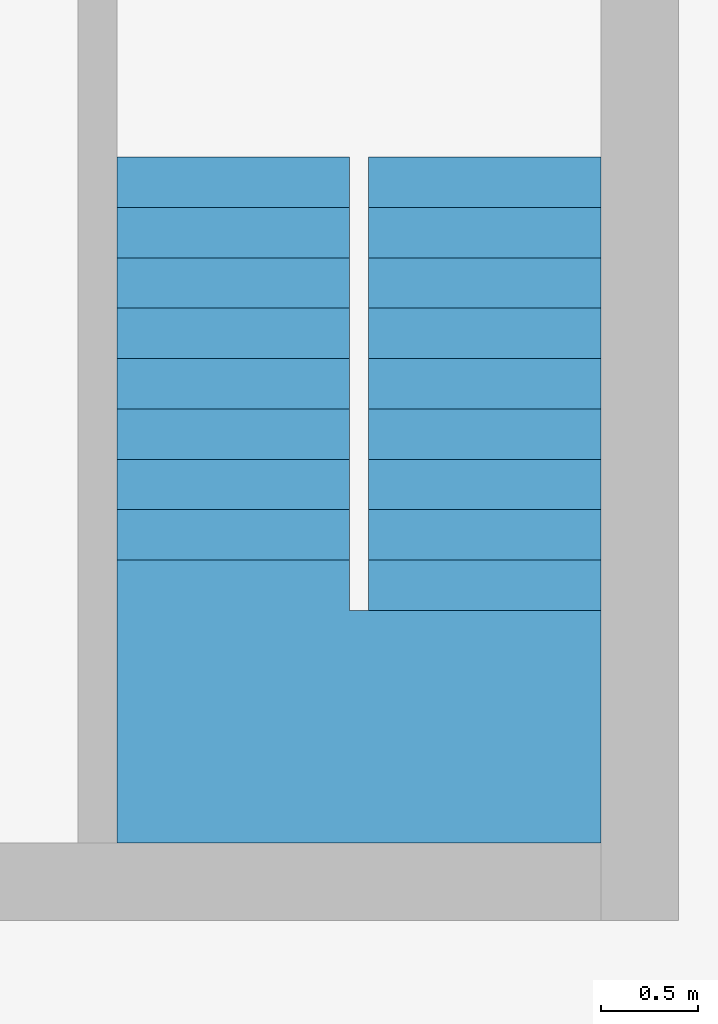
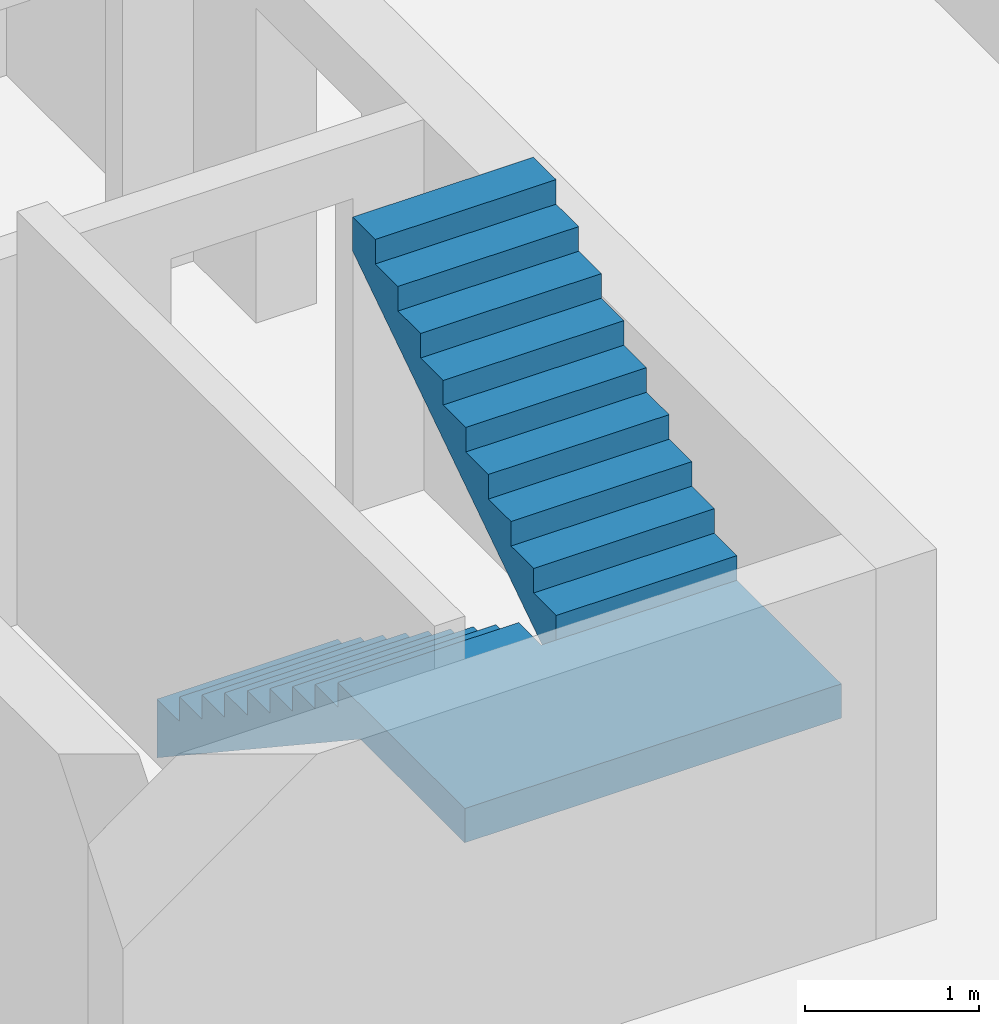
# One storey, part 2 of 2: 1 stair.
"""IFC2X3 building model written with IfcOpenShell, lengths in metres."""

from ifc_helpers import new_model, entity, si_unit, converted_unit, frame, origin, place, context, subcontext, project, spatial, faceted_brep, material, element, save


model = new_model("IFC2X3")

# Units and contexts
model_context = context("Model", 3, precision=1e-05, world=origin())
body_context = subcontext(model_context, "Body", "Model", "MODEL_VIEW")
ifc_project = project(units=[si_unit("LENGTHUNIT", "METRE"), si_unit("AREAUNIT", "SQUARE_METRE"), si_unit("VOLUMEUNIT", "CUBIC_METRE"), si_unit("MASSUNIT", "GRAM", prefix="KILO"), converted_unit("PLANEANGLEUNIT", "DEGREE", entity("IfcPlaneAngleMeasure", 0.0174532925199433), si_unit("PLANEANGLEUNIT", "RADIAN"), dimensions=[0, 0, 0, 0, 0, 0, 0])], contexts=[model_context])

# Site, building, storey
site_placement = place(None, origin())
site = spatial("IfcSite", under=ifc_project, at=site_placement, CompositionType="ELEMENT")
building_placement = place(site_placement, origin())
building = spatial("IfcBuilding", under=site, at=building_placement, CompositionType="ELEMENT")
storey_placement = place(building_placement, frame((0.0, 0.0, -3.1)))
storey = spatial("IfcBuildingStorey", under=building, at=storey_placement, Name="Untergeschoss", CompositionType="ELEMENT", Elevation=-3.1)

# Stair
ifc_material = material(Name="FT_STB C45")
stair_placement = place(storey_placement, frame((22.5, 5.4, -0.240467261695489)))
element("IfcStair", 1, at=stair_placement, inside=storey, material=ifc_material, ShapeType="NOTDEFINED", context=body_context, shape_type="Brep", body=[
    faceted_brep([(1.3, 3.02010000000001, 3.11824503947327), (2.5, 3.02010000000001, 3.11824503947327), (2.5, 3.28010000000001, 3.11824503947327), (1.3, 3.28010000000001, 3.11824503947327), (2.5, 3.02010000000001, 3.16824503947327), (1.3, 3.02010000000001, 3.16824503947327), (1.3, 3.28010000000001, 3.16824503947327), (2.5, 3.28010000000001, 3.16824503947327)], [[[0, 1, 2, 3]], [[4, 5, 6, 7]], [[1, 0, 5, 4]], [[2, 1, 4, 7]], [[3, 2, 7, 6]], [[0, 3, 6, 5]]], orient=[[False], [False], [False], [False], [False], [False]]),
    faceted_brep([(1.3, 2.76010000000001, 2.94602281725104), (2.5, 2.76010000000001, 2.94602281725104), (2.5, 3.02010000000001, 2.94602281725104), (1.3, 3.02010000000001, 2.94602281725104), (2.5, 2.76010000000001, 2.99602281725104), (1.3, 2.76010000000001, 2.99602281725104), (1.3, 3.02010000000001, 2.99602281725104), (2.5, 3.02010000000001, 2.99602281725104)], [[[0, 1, 2, 3]], [[4, 5, 6, 7]], [[1, 0, 5, 4]], [[2, 1, 4, 7]], [[3, 2, 7, 6]], [[0, 3, 6, 5]]], orient=[[False], [False], [False], [False], [False], [False]]),
    faceted_brep([(1.3, 2.50010000000001, 2.77380059502882), (2.5, 2.50010000000001, 2.77380059502882), (2.5, 2.76010000000001, 2.77380059502882), (1.3, 2.76010000000001, 2.77380059502882), (2.5, 2.50010000000001, 2.82380059502882), (1.3, 2.50010000000001, 2.82380059502882), (1.3, 2.76010000000001, 2.82380059502882), (2.5, 2.76010000000001, 2.82380059502882)], [[[0, 1, 2, 3]], [[4, 5, 6, 7]], [[1, 0, 5, 4]], [[2, 1, 4, 7]], [[3, 2, 7, 6]], [[0, 3, 6, 5]]], orient=[[False], [False], [False], [False], [False], [False]]),
    faceted_brep([(1.3, 2.24010000000001, 2.6015783728066), (2.5, 2.24010000000001, 2.6015783728066), (2.5, 2.50010000000001, 2.6015783728066), (1.3, 2.50010000000001, 2.6015783728066), (2.5, 2.24010000000001, 2.6515783728066), (1.3, 2.24010000000001, 2.6515783728066), (1.3, 2.50010000000001, 2.6515783728066), (2.5, 2.50010000000001, 2.6515783728066)], [[[0, 1, 2, 3]], [[4, 5, 6, 7]], [[1, 0, 5, 4]], [[2, 1, 4, 7]], [[3, 2, 7, 6]], [[0, 3, 6, 5]]], orient=[[False], [False], [False], [False], [False], [False]]),
    faceted_brep([(1.3, 1.98010000000001, 2.42935615058438), (2.5, 1.98010000000001, 2.42935615058438), (2.5, 2.24010000000001, 2.42935615058438), (1.3, 2.24010000000001, 2.42935615058438), (2.5, 1.98010000000001, 2.47935615058438), (1.3, 1.98010000000001, 2.47935615058438), (1.3, 2.24010000000001, 2.47935615058438), (2.5, 2.24010000000001, 2.47935615058438)], [[[0, 1, 2, 3]], [[4, 5, 6, 7]], [[1, 0, 5, 4]], [[2, 1, 4, 7]], [[3, 2, 7, 6]], [[0, 3, 6, 5]]], orient=[[False], [False], [False], [False], [False], [False]]),
    faceted_brep([(1.3, 1.72010000000001, 2.25713392836215), (2.5, 1.72010000000001, 2.25713392836215), (2.5, 1.98010000000001, 2.25713392836215), (1.3, 1.98010000000001, 2.25713392836215), (2.5, 1.72010000000001, 2.30713392836215), (1.3, 1.72010000000001, 2.30713392836215), (1.3, 1.98010000000001, 2.30713392836215), (2.5, 1.98010000000001, 2.30713392836215)], [[[0, 1, 2, 3]], [[4, 5, 6, 7]], [[1, 0, 5, 4]], [[2, 1, 4, 7]], [[3, 2, 7, 6]], [[0, 3, 6, 5]]], orient=[[False], [False], [False], [False], [False], [False]]),
    faceted_brep([(1.3, 1.46010000000001, 2.08491170613993), (2.5, 1.46010000000001, 2.08491170613993), (2.5, 1.72010000000001, 2.08491170613993), (1.3, 1.72010000000001, 2.08491170613993), (2.5, 1.46010000000001, 2.13491170613993), (1.3, 1.46010000000001, 2.13491170613993), (1.3, 1.72010000000001, 2.13491170613993), (2.5, 1.72010000000001, 2.13491170613993)], [[[0, 1, 2, 3]], [[4, 5, 6, 7]], [[1, 0, 5, 4]], [[2, 1, 4, 7]], [[3, 2, 7, 6]], [[0, 3, 6, 5]]], orient=[[False], [False], [False], [False], [False], [False]]),
    faceted_brep([(1.3, 1.20010000000001, 1.91268948391771), (2.5, 1.20010000000001, 1.91268948391771), (2.5, 1.46010000000001, 1.91268948391771), (1.3, 1.46010000000001, 1.91268948391771), (2.5, 1.20010000000001, 1.96268948391771), (1.3, 1.20010000000001, 1.96268948391771), (1.3, 1.46010000000001, 1.96268948391771), (2.5, 1.46010000000001, 1.96268948391771)], [[[0, 1, 2, 3]], [[4, 5, 6, 7]], [[1, 0, 5, 4]], [[2, 1, 4, 7]], [[3, 2, 7, 6]], [[0, 3, 6, 5]]], orient=[[False], [False], [False], [False], [False], [False]]),
    faceted_brep([(1.201, 1.2, 1.74046726169549), (1.201, 0.0, 1.74046726169549), (2.5, 0.0, 1.74046726169549), (2.5, 1.20010000000001, 1.74046726169549), (1.3, 1.20010000000001, 1.74046726169549), (1.3, 1.2, 1.74046726169549), (1.201, 0.0, 1.79046726169549), (1.201, 1.2, 1.79046726169549), (1.3, 1.2, 1.79046726169549), (1.3, 1.20010000000001, 1.79046726169549), (2.5, 1.20010000000001, 1.79046726169549), (2.5, 0.0, 1.79046726169549)], [[[0, 1, 2, 3, 4, 5]], [[6, 7, 8, 9, 10, 11]], [[1, 0, 7, 6]], [[2, 1, 6, 11]], [[3, 2, 11, 10]], [[4, 3, 10, 9]], [[5, 4, 9, 8]], [[0, 5, 8, 7]]], orient=[[False], [False], [False], [False], [False], [False], [False], [False]]),
    faceted_brep([(1.2, 1.2001, 1.74046726169549), (0.0, 1.2001, 1.74046726169549), (0.0, 0.0, 1.74046726169549), (1.201, 0.0, 1.74046726169549), (1.201, 1.2, 1.74046726169549), (1.2, 1.2, 1.74046726169549), (0.0, 1.2001, 1.79046726169549), (1.2, 1.2001, 1.79046726169549), (1.2, 1.2, 1.79046726169549), (1.201, 1.2, 1.79046726169549), (1.201, 0.0, 1.79046726169549), (0.0, 0.0, 1.79046726169549)], [[[0, 1, 2, 3, 4, 5]], [[6, 7, 8, 9, 10, 11]], [[1, 0, 7, 6]], [[2, 1, 6, 11]], [[3, 2, 11, 10]], [[4, 3, 10, 9]], [[5, 4, 9, 8]], [[0, 5, 8, 7]]], orient=[[False], [False], [False], [False], [False], [False], [False], [False]]),
    faceted_brep([(1.2, 1.4601, 1.74046726169549), (0.0, 1.4601, 1.74046726169549), (0.0, 1.2001, 1.74046726169549), (1.2, 1.2001, 1.74046726169549), (0.0, 1.4601, 1.79046726169549), (1.2, 1.4601, 1.79046726169549), (1.2, 1.2001, 1.79046726169549), (0.0, 1.2001, 1.79046726169549)], [[[0, 1, 2, 3]], [[4, 5, 6, 7]], [[1, 0, 5, 4]], [[2, 1, 4, 7]], [[3, 2, 7, 6]], [[0, 3, 6, 5]]], orient=[[False], [False], [False], [False], [False], [False]]),
    faceted_brep([(1.2, 1.7201, 1.56824503947327), (0.0, 1.7201, 1.56824503947327), (0.0, 1.4601, 1.56824503947327), (1.2, 1.4601, 1.56824503947327), (0.0, 1.7201, 1.61824503947327), (1.2, 1.7201, 1.61824503947327), (1.2, 1.4601, 1.61824503947327), (0.0, 1.4601, 1.61824503947327)], [[[0, 1, 2, 3]], [[4, 5, 6, 7]], [[1, 0, 5, 4]], [[2, 1, 4, 7]], [[3, 2, 7, 6]], [[0, 3, 6, 5]]], orient=[[False], [False], [False], [False], [False], [False]]),
    faceted_brep([(1.2, 1.9801, 1.39602281725104), (0.0, 1.9801, 1.39602281725104), (0.0, 1.7201, 1.39602281725104), (1.2, 1.7201, 1.39602281725104), (0.0, 1.9801, 1.44602281725104), (1.2, 1.9801, 1.44602281725104), (1.2, 1.7201, 1.44602281725104), (0.0, 1.7201, 1.44602281725104)], [[[0, 1, 2, 3]], [[4, 5, 6, 7]], [[1, 0, 5, 4]], [[2, 1, 4, 7]], [[3, 2, 7, 6]], [[0, 3, 6, 5]]], orient=[[False], [False], [False], [False], [False], [False]]),
    faceted_brep([(1.2, 2.2401, 1.22380059502882), (0.0, 2.2401, 1.22380059502882), (0.0, 1.9801, 1.22380059502882), (1.2, 1.9801, 1.22380059502882), (0.0, 2.2401, 1.27380059502882), (1.2, 2.2401, 1.27380059502882), (1.2, 1.9801, 1.27380059502882), (0.0, 1.9801, 1.27380059502882)], [[[0, 1, 2, 3]], [[4, 5, 6, 7]], [[1, 0, 5, 4]], [[2, 1, 4, 7]], [[3, 2, 7, 6]], [[0, 3, 6, 5]]], orient=[[False], [False], [False], [False], [False], [False]]),
    faceted_brep([(1.2, 2.5001, 1.0515783728066), (0.0, 2.5001, 1.0515783728066), (0.0, 2.2401, 1.0515783728066), (1.2, 2.2401, 1.0515783728066), (0.0, 2.5001, 1.1015783728066), (1.2, 2.5001, 1.1015783728066), (1.2, 2.2401, 1.1015783728066), (0.0, 2.2401, 1.1015783728066)], [[[0, 1, 2, 3]], [[4, 5, 6, 7]], [[1, 0, 5, 4]], [[2, 1, 4, 7]], [[3, 2, 7, 6]], [[0, 3, 6, 5]]], orient=[[False], [False], [False], [False], [False], [False]]),
    faceted_brep([(1.2, 2.7601, 0.879356150584377), (0.0, 2.7601, 0.879356150584377), (0.0, 2.5001, 0.879356150584377), (1.2, 2.5001, 0.879356150584377), (0.0, 2.7601, 0.929356150584377), (1.2, 2.7601, 0.929356150584377), (1.2, 2.5001, 0.929356150584377), (0.0, 2.5001, 0.929356150584377)], [[[0, 1, 2, 3]], [[4, 5, 6, 7]], [[1, 0, 5, 4]], [[2, 1, 4, 7]], [[3, 2, 7, 6]], [[0, 3, 6, 5]]], orient=[[False], [False], [False], [False], [False], [False]]),
    faceted_brep([(1.2, 3.0201, 0.707133928362155), (0.0, 3.0201, 0.707133928362155), (0.0, 2.7601, 0.707133928362155), (1.2, 2.7601, 0.707133928362155), (0.0, 3.0201, 0.757133928362155), (1.2, 3.0201, 0.757133928362155), (1.2, 2.7601, 0.757133928362155), (0.0, 2.7601, 0.757133928362155)], [[[0, 1, 2, 3]], [[4, 5, 6, 7]], [[1, 0, 5, 4]], [[2, 1, 4, 7]], [[3, 2, 7, 6]], [[0, 3, 6, 5]]], orient=[[False], [False], [False], [False], [False], [False]]),
    faceted_brep([(1.2, 3.2801, 0.534911706139933), (0.0, 3.2801, 0.534911706139933), (0.0, 3.0201, 0.534911706139933), (1.2, 3.0201, 0.534911706139933), (0.0, 3.2801, 0.584911706139933), (1.2, 3.2801, 0.584911706139933), (1.2, 3.0201, 0.584911706139933), (0.0, 3.0201, 0.584911706139933)], [[[0, 1, 2, 3]], [[4, 5, 6, 7]], [[1, 0, 5, 4]], [[2, 1, 4, 7]], [[3, 2, 7, 6]], [[0, 3, 6, 5]]], orient=[[False], [False], [False], [False], [False], [False]]),
    faceted_brep([(1.2, 3.5401, 0.362689483917711), (0.0, 3.5401, 0.362689483917711), (0.0, 3.2801, 0.362689483917711), (1.2, 3.2801, 0.362689483917711), (0.0, 3.5401, 0.412689483917711), (1.2, 3.5401, 0.412689483917711), (1.2, 3.2801, 0.412689483917711), (0.0, 3.2801, 0.412689483917711)], [[[0, 1, 2, 3]], [[4, 5, 6, 7]], [[1, 0, 5, 4]], [[2, 1, 4, 7]], [[3, 2, 7, 6]], [[0, 3, 6, 5]]], orient=[[False], [False], [False], [False], [False], [False]]),
    faceted_brep([(1.3, 3.28010000000001, 3.29046726169549), (2.5, 3.28010000000001, 3.29046726169549), (2.5, 3.5401, 3.29046726169549), (1.3, 3.5401, 3.29046726169549), (2.5, 3.28010000000001, 3.34046726169549), (1.3, 3.28010000000001, 3.34046726169549), (1.3, 3.5401, 3.34046726169549), (2.5, 3.5401, 3.34046726169549)], [[[0, 1, 2, 3]], [[4, 5, 6, 7]], [[1, 0, 5, 4]], [[2, 1, 4, 7]], [[3, 2, 7, 6]], [[0, 3, 6, 5]]], orient=[[False], [False], [False], [False], [False], [False]]),
    faceted_brep([(2.5, 3.02010000000001, 2.75555555555555), (2.5, 3.28010000000001, 2.92777777777778), (1.3, 3.28010000000001, 2.92777777777778), (1.3, 3.02010000000001, 2.75555555555555), (1.3, 3.02010000000001, 3.11824503947327), (1.3, 3.28010000000001, 3.11824503947327), (2.5, 3.28010000000001, 3.11824503947327), (2.5, 3.02010000000001, 3.11824503947327)], [[[0, 1, 2, 3]], [[4, 5, 6, 7]], [[3, 4, 7, 0]], [[0, 7, 6, 1]], [[1, 6, 5, 2]], [[2, 5, 4, 3]]], orient=[[False], [False], [False], [False], [False], [False]]),
    faceted_brep([(2.5, 2.76010000000001, 2.58333333333333), (2.5, 3.02010000000001, 2.75555555555555), (1.3, 3.02010000000001, 2.75555555555555), (1.3, 2.76010000000001, 2.58333333333333), (1.3, 2.76010000000001, 2.94602281725104), (1.3, 3.02010000000001, 2.94602281725104), (2.5, 3.02010000000001, 2.94602281725104), (2.5, 2.76010000000001, 2.94602281725104)], [[[0, 1, 2, 3]], [[4, 5, 6, 7]], [[3, 4, 7, 0]], [[0, 7, 6, 1]], [[1, 6, 5, 2]], [[2, 5, 4, 3]]], orient=[[False], [False], [False], [False], [False], [False]]),
    faceted_brep([(2.5, 2.50010000000001, 2.41111111111111), (2.5, 2.76010000000001, 2.58333333333333), (1.3, 2.76010000000001, 2.58333333333333), (1.3, 2.50010000000001, 2.41111111111111), (1.3, 2.50010000000001, 2.77380059502882), (1.3, 2.76010000000001, 2.77380059502882), (2.5, 2.76010000000001, 2.77380059502882), (2.5, 2.50010000000001, 2.77380059502882)], [[[0, 1, 2, 3]], [[4, 5, 6, 7]], [[3, 4, 7, 0]], [[0, 7, 6, 1]], [[1, 6, 5, 2]], [[2, 5, 4, 3]]], orient=[[False], [False], [False], [False], [False], [False]]),
    faceted_brep([(2.5, 2.24010000000001, 2.23888888888889), (2.5, 2.50010000000001, 2.41111111111111), (1.3, 2.50010000000001, 2.41111111111111), (1.3, 2.24010000000001, 2.23888888888889), (1.3, 2.24010000000001, 2.6015783728066), (1.3, 2.50010000000001, 2.6015783728066), (2.5, 2.50010000000001, 2.6015783728066), (2.5, 2.24010000000001, 2.6015783728066)], [[[0, 1, 2, 3]], [[4, 5, 6, 7]], [[3, 4, 7, 0]], [[0, 7, 6, 1]], [[1, 6, 5, 2]], [[2, 5, 4, 3]]], orient=[[False], [False], [False], [False], [False], [False]]),
    faceted_brep([(2.5, 1.98010000000001, 2.06666666666667), (2.5, 2.24010000000001, 2.23888888888889), (1.3, 2.24010000000001, 2.23888888888889), (1.3, 1.98010000000001, 2.06666666666667), (1.3, 1.98010000000001, 2.42935615058438), (1.3, 2.24010000000001, 2.42935615058438), (2.5, 2.24010000000001, 2.42935615058438), (2.5, 1.98010000000001, 2.42935615058438)], [[[0, 1, 2, 3]], [[4, 5, 6, 7]], [[3, 4, 7, 0]], [[0, 7, 6, 1]], [[1, 6, 5, 2]], [[2, 5, 4, 3]]], orient=[[False], [False], [False], [False], [False], [False]]),
    faceted_brep([(2.5, 1.72010000000001, 1.89444444444444), (2.5, 1.98010000000001, 2.06666666666667), (1.3, 1.98010000000001, 2.06666666666667), (1.3, 1.72010000000001, 1.89444444444444), (1.3, 1.72010000000001, 2.25713392836215), (1.3, 1.98010000000001, 2.25713392836215), (2.5, 1.98010000000001, 2.25713392836215), (2.5, 1.72010000000001, 2.25713392836215)], [[[0, 1, 2, 3]], [[4, 5, 6, 7]], [[3, 4, 7, 0]], [[0, 7, 6, 1]], [[1, 6, 5, 2]], [[2, 5, 4, 3]]], orient=[[False], [False], [False], [False], [False], [False]]),
    faceted_brep([(2.5, 1.46010000000001, 1.72222222222222), (2.5, 1.72010000000001, 1.89444444444444), (1.3, 1.72010000000001, 1.89444444444444), (1.3, 1.46010000000001, 1.72222222222222), (1.3, 1.46010000000001, 2.08491170613993), (1.3, 1.72010000000001, 2.08491170613993), (2.5, 1.72010000000001, 2.08491170613993), (2.5, 1.46010000000001, 2.08491170613993)], [[[0, 1, 2, 3]], [[4, 5, 6, 7]], [[3, 4, 7, 0]], [[0, 7, 6, 1]], [[1, 6, 5, 2]], [[2, 5, 4, 3]]], orient=[[False], [False], [False], [False], [False], [False]]),
    faceted_brep([(2.5, 1.20010000000001, 1.55), (2.5, 1.46010000000001, 1.72222222222222), (1.3, 1.46010000000001, 1.72222222222222), (1.3, 1.20010000000001, 1.55), (1.3, 1.20010000000001, 1.91268948391771), (1.3, 1.46010000000001, 1.91268948391771), (2.5, 1.46010000000001, 1.91268948391771), (2.5, 1.20010000000001, 1.91268948391771)], [[[0, 1, 2, 3]], [[4, 5, 6, 7]], [[3, 4, 7, 0]], [[0, 7, 6, 1]], [[1, 6, 5, 2]], [[2, 5, 4, 3]]], orient=[[False], [False], [False], [False], [False], [False]]),
    faceted_brep([(1.201, 1.2, 1.55), (1.201, 0.0, 1.55), (2.5, 0.0, 1.55), (2.5, 1.20010000000001, 1.55), (1.3, 1.20010000000001, 1.55), (1.3, 1.2, 1.55), (1.201, 0.0, 1.74046726169549), (1.201, 1.2, 1.74046726169549), (1.3, 1.2, 1.74046726169549), (1.3, 1.20010000000001, 1.74046726169549), (2.5, 1.20010000000001, 1.74046726169549), (2.5, 0.0, 1.74046726169549)], [[[0, 1, 2, 3, 4, 5]], [[6, 7, 8, 9, 10, 11]], [[1, 0, 7, 6]], [[2, 1, 6, 11]], [[3, 2, 11, 10]], [[4, 3, 10, 9]], [[5, 4, 9, 8]], [[0, 5, 8, 7]]], orient=[[False], [False], [False], [False], [False], [False], [False], [False]]),
    faceted_brep([(1.2, 1.2001, 1.55), (0.0, 1.2001, 1.55), (0.0, 0.0, 1.55), (1.201, 0.0, 1.55), (1.201, 1.2, 1.55), (1.2, 1.2, 1.55), (0.0, 1.2001, 1.74046726169549), (1.2, 1.2001, 1.74046726169549), (1.2, 1.2, 1.74046726169549), (1.201, 1.2, 1.74046726169549), (1.201, 0.0, 1.74046726169549), (0.0, 0.0, 1.74046726169549)], [[[0, 1, 2, 3, 4, 5]], [[6, 7, 8, 9, 10, 11]], [[1, 0, 7, 6]], [[2, 1, 6, 11]], [[3, 2, 11, 10]], [[4, 3, 10, 9]], [[5, 4, 9, 8]], [[0, 5, 8, 7]]], orient=[[False], [False], [False], [False], [False], [False], [False], [False]]),
    faceted_brep([(0.0, 1.4601, 1.37777777777778), (0.0, 1.2001, 1.55), (1.2, 1.2001, 1.55), (1.2, 1.4601, 1.37777777777778), (1.2, 1.4601, 1.74046726169549), (1.2, 1.2001, 1.74046726169549), (0.0, 1.2001, 1.74046726169549), (0.0, 1.4601, 1.74046726169549)], [[[0, 1, 2, 3]], [[4, 5, 6, 7]], [[3, 4, 7, 0]], [[0, 7, 6, 1]], [[1, 6, 5, 2]], [[2, 5, 4, 3]]], orient=[[False], [False], [False], [False], [False], [False]]),
    faceted_brep([(0.0, 1.7201, 1.20555555555555), (0.0, 1.4601, 1.37777777777778), (1.2, 1.4601, 1.37777777777778), (1.2, 1.7201, 1.20555555555555), (1.2, 1.7201, 1.56824503947327), (1.2, 1.4601, 1.56824503947327), (0.0, 1.4601, 1.56824503947327), (0.0, 1.7201, 1.56824503947327)], [[[0, 1, 2, 3]], [[4, 5, 6, 7]], [[3, 4, 7, 0]], [[0, 7, 6, 1]], [[1, 6, 5, 2]], [[2, 5, 4, 3]]], orient=[[False], [False], [False], [False], [False], [False]]),
    faceted_brep([(0.0, 1.9801, 1.03333333333333), (0.0, 1.7201, 1.20555555555556), (1.2, 1.7201, 1.20555555555556), (1.2, 1.9801, 1.03333333333333), (1.2, 1.9801, 1.39602281725104), (1.2, 1.7201, 1.39602281725104), (0.0, 1.7201, 1.39602281725104), (0.0, 1.9801, 1.39602281725104)], [[[0, 1, 2, 3]], [[4, 5, 6, 7]], [[3, 4, 7, 0]], [[0, 7, 6, 1]], [[1, 6, 5, 2]], [[2, 5, 4, 3]]], orient=[[False], [False], [False], [False], [False], [False]]),
    faceted_brep([(0.0, 2.2401, 0.86111111111111), (0.0, 1.9801, 1.03333333333333), (1.2, 1.9801, 1.03333333333333), (1.2, 2.2401, 0.86111111111111), (1.2, 2.2401, 1.22380059502882), (1.2, 1.9801, 1.22380059502882), (0.0, 1.9801, 1.22380059502882), (0.0, 2.2401, 1.22380059502882)], [[[0, 1, 2, 3]], [[4, 5, 6, 7]], [[3, 4, 7, 0]], [[0, 7, 6, 1]], [[1, 6, 5, 2]], [[2, 5, 4, 3]]], orient=[[False], [False], [False], [False], [False], [False]]),
    faceted_brep([(0.0, 2.5001, 0.688888888888889), (0.0, 2.2401, 0.861111111111111), (1.2, 2.2401, 0.861111111111111), (1.2, 2.5001, 0.688888888888889), (1.2, 2.5001, 1.0515783728066), (1.2, 2.2401, 1.0515783728066), (0.0, 2.2401, 1.0515783728066), (0.0, 2.5001, 1.0515783728066)], [[[0, 1, 2, 3]], [[4, 5, 6, 7]], [[3, 4, 7, 0]], [[0, 7, 6, 1]], [[1, 6, 5, 2]], [[2, 5, 4, 3]]], orient=[[False], [False], [False], [False], [False], [False]]),
    faceted_brep([(0.0, 2.7601, 0.516666666666666), (0.0, 2.5001, 0.688888888888889), (1.2, 2.5001, 0.688888888888889), (1.2, 2.7601, 0.516666666666666), (1.2, 2.7601, 0.879356150584377), (1.2, 2.5001, 0.879356150584377), (0.0, 2.5001, 0.879356150584377), (0.0, 2.7601, 0.879356150584377)], [[[0, 1, 2, 3]], [[4, 5, 6, 7]], [[3, 4, 7, 0]], [[0, 7, 6, 1]], [[1, 6, 5, 2]], [[2, 5, 4, 3]]], orient=[[False], [False], [False], [False], [False], [False]]),
    faceted_brep([(0.0, 3.0201, 0.344444444444444), (0.0, 2.7601, 0.516666666666667), (1.2, 2.7601, 0.516666666666667), (1.2, 3.0201, 0.344444444444444), (1.2, 3.0201, 0.707133928362155), (1.2, 2.7601, 0.707133928362155), (0.0, 2.7601, 0.707133928362155), (0.0, 3.0201, 0.707133928362155)], [[[0, 1, 2, 3]], [[4, 5, 6, 7]], [[3, 4, 7, 0]], [[0, 7, 6, 1]], [[1, 6, 5, 2]], [[2, 5, 4, 3]]], orient=[[False], [False], [False], [False], [False], [False]]),
    faceted_brep([(0.0, 3.2801, 0.172222222222222), (0.0, 3.0201, 0.344444444444444), (1.2, 3.0201, 0.344444444444444), (1.2, 3.2801, 0.172222222222222), (1.2, 3.2801, 0.534911706139933), (1.2, 3.0201, 0.534911706139933), (0.0, 3.0201, 0.534911706139933), (0.0, 3.2801, 0.534911706139933)], [[[0, 1, 2, 3]], [[4, 5, 6, 7]], [[3, 4, 7, 0]], [[0, 7, 6, 1]], [[1, 6, 5, 2]], [[2, 5, 4, 3]]], orient=[[False], [False], [False], [False], [False], [False]]),
    faceted_brep([(0.0, 3.5401, 0.0), (0.0, 3.2801, 0.172222222222222), (1.2, 3.2801, 0.172222222222222), (1.2, 3.5401, 0.0), (1.2, 3.5401, 0.362689483917711), (1.2, 3.2801, 0.362689483917711), (0.0, 3.2801, 0.362689483917711), (0.0, 3.5401, 0.362689483917711)], [[[0, 1, 2, 3]], [[4, 5, 6, 7]], [[3, 4, 7, 0]], [[0, 7, 6, 1]], [[1, 6, 5, 2]], [[2, 5, 4, 3]]], orient=[[False], [False], [False], [False], [False], [False]]),
    faceted_brep([(2.5, 3.28010000000001, 2.92777777777778), (2.5, 3.5401, 3.1), (1.3, 3.5401, 3.1), (1.3, 3.28010000000001, 2.92777777777778), (1.3, 3.28010000000001, 3.29046726169549), (1.3, 3.5401, 3.29046726169549), (2.5, 3.5401, 3.29046726169549), (2.5, 3.28010000000001, 3.29046726169549)], [[[0, 1, 2, 3]], [[4, 5, 6, 7]], [[3, 4, 7, 0]], [[0, 7, 6, 1]], [[1, 6, 5, 2]], [[2, 5, 4, 3]]], orient=[[False], [False], [False], [False], [False], [False]]),
])

save(model, "model.ifc")
